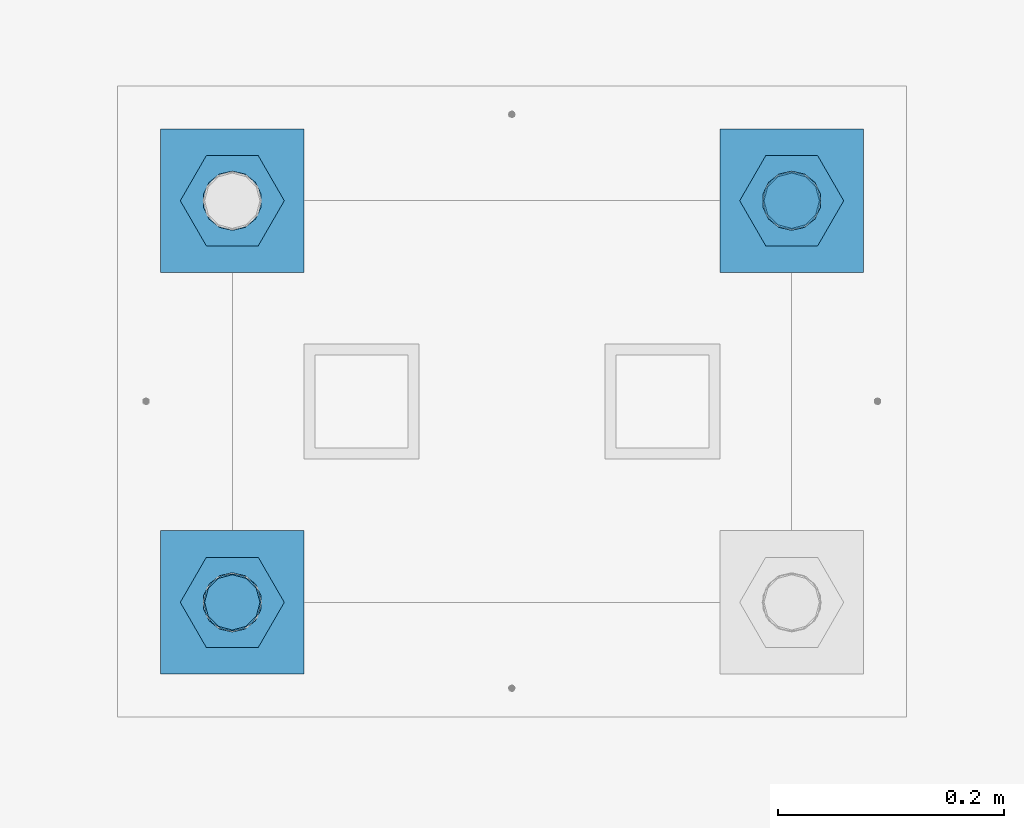
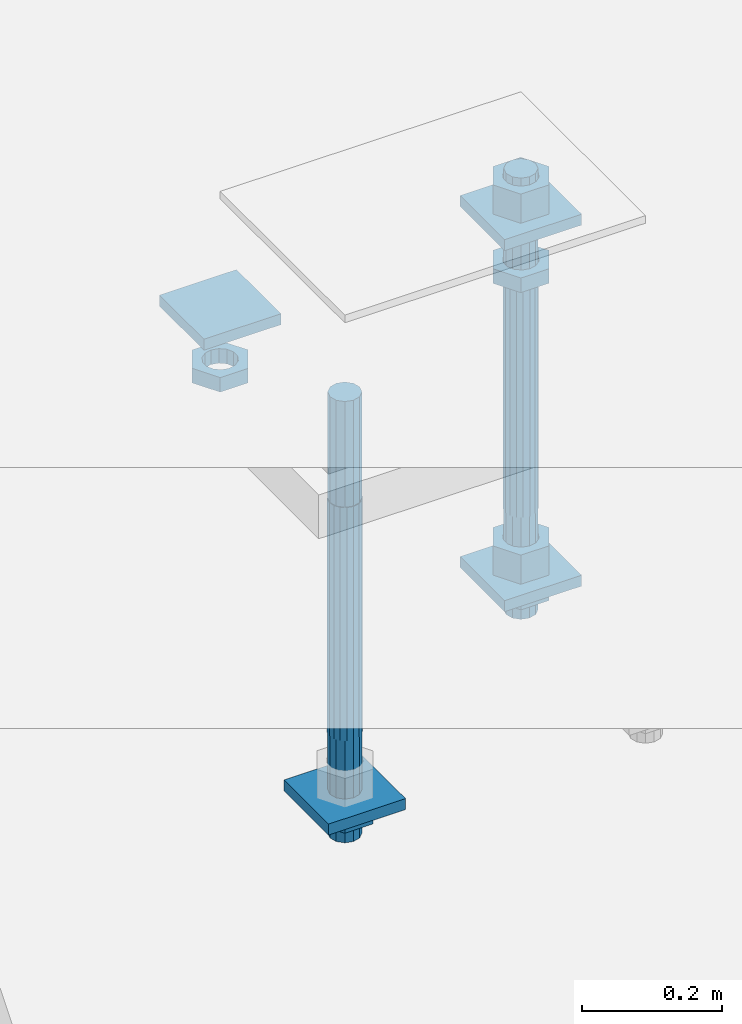
# One storey, part 2717 of 3843: 12 beams, 1 element without a shape of its own.
"""IFC2X3 building model written with IfcOpenShell, lengths in millimetres."""

from ifc_helpers import new_model, si_unit, frame, origin_with_axes, place, context, subcontext, project, spatial, faceted_brep, material, type_object, element, aggregate, save


model = new_model("IFC2X3")

# Units and contexts
model_context = context("Model", 3, precision=1e-05, world=origin_with_axes())
body_context = subcontext(model_context, "Body", "Model", "MODEL_VIEW")
ifc_project = project(units=[si_unit("LENGTHUNIT", "METRE", prefix="MILLI"), si_unit("AREAUNIT", "SQUARE_METRE"), si_unit("VOLUMEUNIT", "CUBIC_METRE"), si_unit("MASSUNIT", "GRAM", prefix="KILO"), si_unit("TIMEUNIT", "SECOND"), si_unit("PLANEANGLEUNIT", "RADIAN"), si_unit("SOLIDANGLEUNIT", "STERADIAN"), si_unit("THERMODYNAMICTEMPERATUREUNIT", "DEGREE_CELSIUS"), si_unit("LUMINOUSINTENSITYUNIT", "LUMEN")], contexts=[model_context])

# Site, building, storey
site_placement = place(None, origin_with_axes())
site = spatial("IfcSite", under=ifc_project, at=site_placement, CompositionType="ELEMENT")
building_placement = place(site_placement, origin_with_axes())
building = spatial("IfcBuilding", under=site, at=building_placement, Name="Undefined", CompositionType="ELEMENT")
storey_placement = place(building_placement, origin_with_axes())
storey = spatial("IfcBuildingStorey", under=building, at=storey_placement, Name="Undefined", CompositionType="ELEMENT", Elevation=0.0)

# Assembly, beams
assembly_placement = place(storey_placement, origin_with_axes())
assembly = element("IfcElementAssembly", 1, at=assembly_placement, inside=storey, Name="TEMPLATE", AssemblyPlace="NOTDEFINED", PredefinedType="RIGID_FRAME")
ifc_material_1 = material(Name="STEEL/A572-50")
beam_type_1 = type_object("IfcBeamType", PredefinedType="NOTDEFINED")
beam_1_placement = place(assembly_placement, frame((105403.65, 52946.2999984741, 29873.575), z_axis=(-1.0, 0.0, 0.0), x_axis=(0.0, -1.0, 0.0)))
beam_1 = element("IfcBeam", 2, at=beam_1_placement, type_object=beam_type_1, material=ifc_material_1, Name="WASHER_PLATE", context=body_context, shape_type="Brep", body=[
    faceted_brep([(0.0, 9.52500000000146, -63.5), (0.0, 9.52500000000146, 63.5), (127.0, 9.52500000000146, 63.5), (127.0, 9.52500000000146, -63.5), (0.0, -9.52500000000146, 63.5), (127.0, -9.52500000000146, 63.5), (0.0, -9.52500000000146, -63.5), (127.0, -9.52500000000146, -63.5)], [[[0, 1, 2, 3]], [[1, 4, 5, 2]], [[4, 6, 7, 5]], [[6, 0, 3, 7]], [[5, 7, 3, 2]], [[6, 4, 1, 0]]]),
])
beam_2_placement = place(assembly_placement, frame((104908.35, 52946.2999984741, 29873.575), z_axis=(-1.0, 0.0, 0.0), x_axis=(0.0, -1.0, 0.0)))
beam_2 = element("IfcBeam", 3, at=beam_2_placement, type_object=beam_type_1, material=ifc_material_1, Name="WASHER_PLATE", context=body_context, shape_type="Brep", body=[
    faceted_brep([(0.0, 9.52500000000146, -63.5), (0.0, 9.52500000000146, 63.5), (127.0, 9.52500000000146, 63.5), (127.0, 9.52500000000146, -63.5), (0.0, -9.52500000000146, 63.5), (127.0, -9.52500000000146, 63.5), (0.0, -9.52500000000146, -63.5), (127.0, -9.52500000000146, -63.5)], [[[0, 1, 2, 3]], [[1, 4, 5, 2]], [[4, 6, 7, 5]], [[6, 0, 3, 7]], [[5, 7, 3, 2]], [[6, 4, 1, 0]]]),
])
beam_3_placement = place(assembly_placement, frame((105403.65, 52946.2999984741, 29244.925), z_axis=(-1.0, 0.0, 0.0), x_axis=(0.0, -1.0, 0.0)))
beam_3 = element("IfcBeam", 4, at=beam_3_placement, type_object=beam_type_1, material=ifc_material_1, Name="WASHER_PLATE", context=body_context, shape_type="Brep", body=[
    faceted_brep([(0.0, 9.52500000000146, -63.5), (0.0, 9.52500000000146, 63.5), (127.0, 9.52500000000146, 63.5), (127.0, 9.52500000000146, -63.5), (0.0, -9.52500000000146, 63.5), (127.0, -9.52500000000146, 63.5), (0.0, -9.52500000000146, -63.5), (127.0, -9.52500000000146, -63.5)], [[[0, 1, 2, 3]], [[1, 4, 5, 2]], [[4, 6, 7, 5]], [[6, 0, 3, 7]], [[5, 7, 3, 2]], [[6, 4, 1, 0]]]),
])
beam_4_placement = place(assembly_placement, frame((104908.35, 52590.6999984741, 29244.925), z_axis=(-1.0, 0.0, 0.0), x_axis=(0.0, -1.0, 0.0)))
beam_4 = element("IfcBeam", 5, at=beam_4_placement, type_object=beam_type_1, material=ifc_material_1, Name="WASHER_PLATE", context=body_context, shape_type="Brep", body=[
    faceted_brep([(0.0, 9.52500000000146, -63.5), (0.0, 9.52500000000146, 63.5), (127.0, 9.52500000000146, 63.5), (127.0, 9.52500000000146, -63.5), (0.0, -9.52500000000146, 63.5), (127.0, -9.52500000000146, 63.5), (0.0, -9.52500000000146, -63.5), (127.0, -9.52500000000146, -63.5)], [[[0, 1, 2, 3]], [[1, 4, 5, 2]], [[4, 6, 7, 5]], [[6, 0, 3, 7]], [[5, 7, 3, 2]], [[6, 4, 1, 0]]]),
])
ifc_material_2 = material(Name="STEEL/A36")
beam_type_2 = type_object("IfcBeamType", Name="2_HALF_NUT", PredefinedType="NOTDEFINED")
beam_5_placement = place(assembly_placement, frame((105403.65, 52882.7999984741, 29787.85), z_axis=(0.0, -1.0, 0.0), x_axis=(0.0, 0.0, -1.0)))
beam_5 = element("IfcBeam", 6, at=beam_5_placement, type_object=beam_type_2, material=ifc_material_2, Name="NUT", ObjectType="2_HALF_NUT", context=body_context, shape_type="Brep", body=[
    faceted_brep([(0.0, -46.0369987487793, 0.0), (0.0, -23.0184993743896, -39.869213104248), (25.4000000000015, -23.0184993743896, -39.869213104248), (25.4000000000015, -46.0369987487793, 0.0), (0.0, 23.0184993743896, -39.869213104248), (25.4000000000015, 23.0184993743896, -39.869213104248), (0.0, 46.0369987487793, 0.0), (25.4000000000015, 46.0369987487793, 0.0), (0.0, 23.0184993743896, 39.869213104248), (25.4000000000015, 23.0184993743896, 39.869213104248), (0.0, -23.0184993743896, 39.869213104248), (25.4000000000015, -23.0184993743896, 39.869213104248), (0.0, 0.0, 26.1940002441406), (0.0, 11.3650617044477, 23.5999013092805), (25.4000000000015, 11.3650617044477, 23.5999013092805), (25.4000000000015, 0.0, 26.1940002441406), (0.0, 20.4791109456419, 16.3316083006721), (25.4000000000015, 20.4791109456419, 16.3316083006721), (0.0, 25.5370200498292, 5.82867859874386), (25.4000000000015, 25.5370200498292, 5.82867859874386), (0.0, 25.5370200498292, -5.82867859874386), (25.4000000000015, 25.5370200498292, -5.82867859874386), (0.0, 20.4791109456419, -16.3316083006721), (25.4000000000015, 20.4791109456419, -16.3316083006721), (0.0, 11.3650617044477, -23.5999013092805), (25.4000000000015, 11.3650617044477, -23.5999013092805), (0.0, 0.0, -26.1940002441406), (25.4000000000015, 0.0, -26.1940002441406), (0.0, -11.3650617044477, -23.5999013092805), (25.4000000000015, -11.3650617044477, -23.5999013092805), (0.0, -20.4791109456419, -16.3316083006721), (25.4000000000015, -20.4791109456419, -16.3316083006721), (0.0, -25.5370200498292, -5.82867859874386), (25.4000000000015, -25.5370200498292, -5.82867859874386), (0.0, -25.5370200498292, 5.82867859874386), (25.4000000000015, -25.5370200498292, 5.82867859874386), (0.0, -20.4791109456419, 16.3316083006721), (25.4000000000015, -20.4791109456419, 16.3316083006721), (0.0, -11.3650617044477, 23.5999013092805), (25.4000000000015, -11.3650617044477, 23.5999013092805)], [[[0, 1, 2, 3]], [[1, 4, 5, 2]], [[4, 6, 7, 5]], [[6, 8, 9, 7]], [[8, 10, 11, 9]], [[10, 0, 3, 11]], [[12, 13, 14, 15]], [[13, 16, 17, 14]], [[16, 18, 19, 17]], [[18, 20, 21, 19]], [[20, 22, 23, 21]], [[22, 24, 25, 23]], [[24, 26, 27, 25]], [[26, 28, 29, 27]], [[28, 30, 31, 29]], [[30, 32, 33, 31]], [[32, 34, 35, 33]], [[34, 36, 37, 35]], [[36, 38, 39, 37]], [[38, 12, 15, 39]], [[5, 7, 9, 11, 3, 2], [17, 19, 21, 23, 25, 27, 29, 31, 33, 35, 37, 39, 15, 14]], [[10, 8, 6, 4, 1, 0], [38, 36, 34, 32, 30, 28, 26, 24, 22, 20, 18, 16, 13, 12]]]),
])
beam_6_placement = place(assembly_placement, frame((105403.65, 52882.7999984741, 29235.4), z_axis=(0.0, -1.0, 0.0), x_axis=(0.0, 0.0, -1.0)))
beam_6 = element("IfcBeam", 7, at=beam_6_placement, type_object=beam_type_2, material=ifc_material_2, Name="NUT", ObjectType="2_HALF_NUT", context=body_context, shape_type="Brep", body=[
    faceted_brep([(0.0, -46.0369987487793, 0.0), (0.0, -23.0184993743896, -39.869213104248), (25.4000000000015, -23.0184993743896, -39.869213104248), (25.4000000000015, -46.0369987487793, 0.0), (0.0, 23.0184993743896, -39.869213104248), (25.4000000000015, 23.0184993743896, -39.869213104248), (0.0, 46.0369987487793, 0.0), (25.4000000000015, 46.0369987487793, 0.0), (0.0, 23.0184993743896, 39.869213104248), (25.4000000000015, 23.0184993743896, 39.869213104248), (0.0, -23.0184993743896, 39.869213104248), (25.4000000000015, -23.0184993743896, 39.869213104248), (0.0, 0.0, 26.1940002441406), (0.0, 11.3650617044477, 23.5999013092805), (25.4000000000015, 11.3650617044477, 23.5999013092805), (25.4000000000015, 0.0, 26.1940002441406), (0.0, 20.4791109456419, 16.3316083006721), (25.4000000000015, 20.4791109456419, 16.3316083006721), (0.0, 25.5370200498292, 5.82867859874386), (25.4000000000015, 25.5370200498292, 5.82867859874386), (0.0, 25.5370200498292, -5.82867859874386), (25.4000000000015, 25.5370200498292, -5.82867859874386), (0.0, 20.4791109456419, -16.3316083006721), (25.4000000000015, 20.4791109456419, -16.3316083006721), (0.0, 11.3650617044477, -23.5999013092805), (25.4000000000015, 11.3650617044477, -23.5999013092805), (0.0, 0.0, -26.1940002441406), (25.4000000000015, 0.0, -26.1940002441406), (0.0, -11.3650617044477, -23.5999013092805), (25.4000000000015, -11.3650617044477, -23.5999013092805), (0.0, -20.4791109456419, -16.3316083006721), (25.4000000000015, -20.4791109456419, -16.3316083006721), (0.0, -25.5370200498292, -5.82867859874386), (25.4000000000015, -25.5370200498292, -5.82867859874386), (0.0, -25.5370200498292, 5.82867859874386), (25.4000000000015, -25.5370200498292, 5.82867859874386), (0.0, -20.4791109456419, 16.3316083006721), (25.4000000000015, -20.4791109456419, 16.3316083006721), (0.0, -11.3650617044477, 23.5999013092805), (25.4000000000015, -11.3650617044477, 23.5999013092805)], [[[0, 1, 2, 3]], [[1, 4, 5, 2]], [[4, 6, 7, 5]], [[6, 8, 9, 7]], [[8, 10, 11, 9]], [[10, 0, 3, 11]], [[12, 13, 14, 15]], [[13, 16, 17, 14]], [[16, 18, 19, 17]], [[18, 20, 21, 19]], [[20, 22, 23, 21]], [[22, 24, 25, 23]], [[24, 26, 27, 25]], [[26, 28, 29, 27]], [[28, 30, 31, 29]], [[30, 32, 33, 31]], [[32, 34, 35, 33]], [[34, 36, 37, 35]], [[36, 38, 39, 37]], [[38, 12, 15, 39]], [[5, 7, 9, 11, 3, 2], [17, 19, 21, 23, 25, 27, 29, 31, 33, 35, 37, 39, 15, 14]], [[10, 8, 6, 4, 1, 0], [38, 36, 34, 32, 30, 28, 26, 24, 22, 20, 18, 16, 13, 12]]]),
])
beam_7_placement = place(assembly_placement, frame((104908.35, 52882.7999984741, 29787.85), z_axis=(0.0, -1.0, 0.0), x_axis=(0.0, 0.0, -1.0)))
beam_7 = element("IfcBeam", 8, at=beam_7_placement, type_object=beam_type_2, material=ifc_material_2, Name="NUT", ObjectType="2_HALF_NUT", context=body_context, shape_type="Brep", body=[
    faceted_brep([(0.0, -46.0369987487793, 0.0), (0.0, -23.0184993743896, -39.869213104248), (25.4000000000015, -23.0184993743896, -39.869213104248), (25.4000000000015, -46.0369987487793, 0.0), (0.0, 23.0184993743896, -39.869213104248), (25.4000000000015, 23.0184993743896, -39.869213104248), (0.0, 46.0369987487793, 0.0), (25.4000000000015, 46.0369987487793, 0.0), (0.0, 23.0184993743896, 39.869213104248), (25.4000000000015, 23.0184993743896, 39.869213104248), (0.0, -23.0184993743896, 39.869213104248), (25.4000000000015, -23.0184993743896, 39.869213104248), (0.0, 0.0, 26.1940002441406), (0.0, 11.3650617044477, 23.5999013092805), (25.4000000000015, 11.3650617044477, 23.5999013092805), (25.4000000000015, 0.0, 26.1940002441406), (0.0, 20.4791109456419, 16.3316083006721), (25.4000000000015, 20.4791109456419, 16.3316083006721), (0.0, 25.5370200498292, 5.82867859874386), (25.4000000000015, 25.5370200498292, 5.82867859874386), (0.0, 25.5370200498292, -5.82867859874386), (25.4000000000015, 25.5370200498292, -5.82867859874386), (0.0, 20.4791109456419, -16.3316083006721), (25.4000000000015, 20.4791109456419, -16.3316083006721), (0.0, 11.3650617044477, -23.5999013092805), (25.4000000000015, 11.3650617044477, -23.5999013092805), (0.0, 0.0, -26.1940002441406), (25.4000000000015, 0.0, -26.1940002441406), (0.0, -11.3650617044477, -23.5999013092805), (25.4000000000015, -11.3650617044477, -23.5999013092805), (0.0, -20.4791109456419, -16.3316083006721), (25.4000000000015, -20.4791109456419, -16.3316083006721), (0.0, -25.5370200498292, -5.82867859874386), (25.4000000000015, -25.5370200498292, -5.82867859874386), (0.0, -25.5370200498292, 5.82867859874386), (25.4000000000015, -25.5370200498292, 5.82867859874386), (0.0, -20.4791109456419, 16.3316083006721), (25.4000000000015, -20.4791109456419, 16.3316083006721), (0.0, -11.3650617044477, 23.5999013092805), (25.4000000000015, -11.3650617044477, 23.5999013092805)], [[[0, 1, 2, 3]], [[1, 4, 5, 2]], [[4, 6, 7, 5]], [[6, 8, 9, 7]], [[8, 10, 11, 9]], [[10, 0, 3, 11]], [[12, 13, 14, 15]], [[13, 16, 17, 14]], [[16, 18, 19, 17]], [[18, 20, 21, 19]], [[20, 22, 23, 21]], [[22, 24, 25, 23]], [[24, 26, 27, 25]], [[26, 28, 29, 27]], [[28, 30, 31, 29]], [[30, 32, 33, 31]], [[32, 34, 35, 33]], [[34, 36, 37, 35]], [[36, 38, 39, 37]], [[38, 12, 15, 39]], [[5, 7, 9, 11, 3, 2], [17, 19, 21, 23, 25, 27, 29, 31, 33, 35, 37, 39, 15, 14]], [[10, 8, 6, 4, 1, 0], [38, 36, 34, 32, 30, 28, 26, 24, 22, 20, 18, 16, 13, 12]]]),
])
beam_8_placement = place(assembly_placement, frame((104908.35, 52527.1999984741, 29235.4), z_axis=(0.0, -1.0, 0.0), x_axis=(0.0, 0.0, -1.0)))
beam_8 = element("IfcBeam", 9, at=beam_8_placement, type_object=beam_type_2, material=ifc_material_2, Name="NUT", ObjectType="2_HALF_NUT", context=body_context, shape_type="Brep", body=[
    faceted_brep([(0.0, -46.0369987487793, 0.0), (0.0, -23.0184993743896, -39.869213104248), (25.4000000000015, -23.0184993743896, -39.869213104248), (25.4000000000015, -46.0369987487793, 0.0), (0.0, 23.0184993743896, -39.869213104248), (25.4000000000015, 23.0184993743896, -39.869213104248), (0.0, 46.0369987487793, 0.0), (25.4000000000015, 46.0369987487793, 0.0), (0.0, 23.0184993743896, 39.869213104248), (25.4000000000015, 23.0184993743896, 39.869213104248), (0.0, -23.0184993743896, 39.869213104248), (25.4000000000015, -23.0184993743896, 39.869213104248), (0.0, 0.0, 26.1940002441406), (0.0, 11.3650617044477, 23.5999013092805), (25.4000000000015, 11.3650617044477, 23.5999013092805), (25.4000000000015, 0.0, 26.1940002441406), (0.0, 20.4791109456419, 16.3316083006721), (25.4000000000015, 20.4791109456419, 16.3316083006721), (0.0, 25.5370200498292, 5.82867859874386), (25.4000000000015, 25.5370200498292, 5.82867859874386), (0.0, 25.5370200498292, -5.82867859874386), (25.4000000000015, 25.5370200498292, -5.82867859874386), (0.0, 20.4791109456419, -16.3316083006721), (25.4000000000015, 20.4791109456419, -16.3316083006721), (0.0, 11.3650617044477, -23.5999013092805), (25.4000000000015, 11.3650617044477, -23.5999013092805), (0.0, 0.0, -26.1940002441406), (25.4000000000015, 0.0, -26.1940002441406), (0.0, -11.3650617044477, -23.5999013092805), (25.4000000000015, -11.3650617044477, -23.5999013092805), (0.0, -20.4791109456419, -16.3316083006721), (25.4000000000015, -20.4791109456419, -16.3316083006721), (0.0, -25.5370200498292, -5.82867859874386), (25.4000000000015, -25.5370200498292, -5.82867859874386), (0.0, -25.5370200498292, 5.82867859874386), (25.4000000000015, -25.5370200498292, 5.82867859874386), (0.0, -20.4791109456419, 16.3316083006721), (25.4000000000015, -20.4791109456419, 16.3316083006721), (0.0, -11.3650617044477, 23.5999013092805), (25.4000000000015, -11.3650617044477, 23.5999013092805)], [[[0, 1, 2, 3]], [[1, 4, 5, 2]], [[4, 6, 7, 5]], [[6, 8, 9, 7]], [[8, 10, 11, 9]], [[10, 0, 3, 11]], [[12, 13, 14, 15]], [[13, 16, 17, 14]], [[16, 18, 19, 17]], [[18, 20, 21, 19]], [[20, 22, 23, 21]], [[22, 24, 25, 23]], [[24, 26, 27, 25]], [[26, 28, 29, 27]], [[28, 30, 31, 29]], [[30, 32, 33, 31]], [[32, 34, 35, 33]], [[34, 36, 37, 35]], [[36, 38, 39, 37]], [[38, 12, 15, 39]], [[5, 7, 9, 11, 3, 2], [17, 19, 21, 23, 25, 27, 29, 31, 33, 35, 37, 39, 15, 14]], [[10, 8, 6, 4, 1, 0], [38, 36, 34, 32, 30, 28, 26, 24, 22, 20, 18, 16, 13, 12]]]),
])
beam_type_3 = type_object("IfcBeamType", Name="2_HEAVY_HEX_NUT", PredefinedType="NOTDEFINED")
beam_9_placement = place(assembly_placement, frame((105403.65, 52882.7999984741, 29933.9), z_axis=(0.0, -1.0, 0.0), x_axis=(0.0, 0.0, -1.0)))
beam_9 = element("IfcBeam", 10, at=beam_9_placement, type_object=beam_type_3, material=ifc_material_2, Name="NUT", ObjectType="2_HEAVY_HEX_NUT", context=body_context, shape_type="Brep", body=[
    faceted_brep([(0.0, -46.0369987487793, 0.0), (0.0, -23.0184993743896, -39.869213104248), (50.7999999999993, -23.0184993743896, -39.869213104248), (50.7999999999993, -46.0369987487793, 0.0), (0.0, 23.0184993743896, -39.869213104248), (50.7999999999993, 23.0184993743896, -39.869213104248), (0.0, 46.0369987487793, 0.0), (50.7999999999993, 46.0369987487793, 0.0), (0.0, 23.0184993743896, 39.869213104248), (50.7999999999993, 23.0184993743896, 39.869213104248), (0.0, -23.0184993743896, 39.869213104248), (50.7999999999993, -23.0184993743896, 39.869213104248), (0.0, 0.0, 26.1940002441406), (0.0, 11.3650617044477, 23.5999013092805), (50.7999999999993, 11.3650617044477, 23.5999013092805), (50.7999999999993, 0.0, 26.1940002441406), (0.0, 20.4791109456419, 16.3316083006721), (50.7999999999993, 20.4791109456419, 16.3316083006721), (0.0, 25.5370200498292, 5.82867859874386), (50.7999999999993, 25.5370200498292, 5.82867859874386), (0.0, 25.5370200498292, -5.82867859874386), (50.7999999999993, 25.5370200498292, -5.82867859874386), (0.0, 20.4791109456419, -16.3316083006721), (50.7999999999993, 20.4791109456419, -16.3316083006721), (0.0, 11.3650617044477, -23.5999013092805), (50.7999999999993, 11.3650617044477, -23.5999013092805), (0.0, 0.0, -26.1940002441406), (50.7999999999993, 0.0, -26.1940002441406), (0.0, -11.3650617044477, -23.5999013092805), (50.7999999999993, -11.3650617044477, -23.5999013092805), (0.0, -20.4791109456419, -16.3316083006721), (50.7999999999993, -20.4791109456419, -16.3316083006721), (0.0, -25.5370200498292, -5.82867859874386), (50.7999999999993, -25.5370200498292, -5.82867859874386), (0.0, -25.5370200498292, 5.82867859874386), (50.7999999999993, -25.5370200498292, 5.82867859874386), (0.0, -20.4791109456419, 16.3316083006721), (50.7999999999993, -20.4791109456419, 16.3316083006721), (0.0, -11.3650617044477, 23.5999013092805), (50.7999999999993, -11.3650617044477, 23.5999013092805)], [[[0, 1, 2, 3]], [[1, 4, 5, 2]], [[4, 6, 7, 5]], [[6, 8, 9, 7]], [[8, 10, 11, 9]], [[10, 0, 3, 11]], [[12, 13, 14, 15]], [[13, 16, 17, 14]], [[16, 18, 19, 17]], [[18, 20, 21, 19]], [[20, 22, 23, 21]], [[22, 24, 25, 23]], [[24, 26, 27, 25]], [[26, 28, 29, 27]], [[28, 30, 31, 29]], [[30, 32, 33, 31]], [[32, 34, 35, 33]], [[34, 36, 37, 35]], [[36, 38, 39, 37]], [[38, 12, 15, 39]], [[5, 7, 9, 11, 3, 2], [17, 19, 21, 23, 25, 27, 29, 31, 33, 35, 37, 39, 15, 14]], [[10, 8, 6, 4, 1, 0], [38, 36, 34, 32, 30, 28, 26, 24, 22, 20, 18, 16, 13, 12]]]),
])
beam_10_placement = place(assembly_placement, frame((105403.65, 52882.7999984741, 29305.25), z_axis=(0.0, -1.0, 0.0), x_axis=(0.0, 0.0, -1.0)))
beam_10 = element("IfcBeam", 11, at=beam_10_placement, type_object=beam_type_3, material=ifc_material_2, Name="NUT", ObjectType="2_HEAVY_HEX_NUT", context=body_context, shape_type="Brep", body=[
    faceted_brep([(0.0, -46.0369987487793, 0.0), (0.0, -23.0184993743896, -39.869213104248), (50.7999999999993, -23.0184993743896, -39.869213104248), (50.7999999999993, -46.0369987487793, 0.0), (0.0, 23.0184993743896, -39.869213104248), (50.7999999999993, 23.0184993743896, -39.869213104248), (0.0, 46.0369987487793, 0.0), (50.7999999999993, 46.0369987487793, 0.0), (0.0, 23.0184993743896, 39.869213104248), (50.7999999999993, 23.0184993743896, 39.869213104248), (0.0, -23.0184993743896, 39.869213104248), (50.7999999999993, -23.0184993743896, 39.869213104248), (0.0, 0.0, 26.1940002441406), (0.0, 11.3650617044477, 23.5999013092805), (50.7999999999993, 11.3650617044477, 23.5999013092805), (50.7999999999993, 0.0, 26.1940002441406), (0.0, 20.4791109456419, 16.3316083006721), (50.7999999999993, 20.4791109456419, 16.3316083006721), (0.0, 25.5370200498292, 5.82867859874386), (50.7999999999993, 25.5370200498292, 5.82867859874386), (0.0, 25.5370200498292, -5.82867859874386), (50.7999999999993, 25.5370200498292, -5.82867859874386), (0.0, 20.4791109456419, -16.3316083006721), (50.7999999999993, 20.4791109456419, -16.3316083006721), (0.0, 11.3650617044477, -23.5999013092805), (50.7999999999993, 11.3650617044477, -23.5999013092805), (0.0, 0.0, -26.1940002441406), (50.7999999999993, 0.0, -26.1940002441406), (0.0, -11.3650617044477, -23.5999013092805), (50.7999999999993, -11.3650617044477, -23.5999013092805), (0.0, -20.4791109456419, -16.3316083006721), (50.7999999999993, -20.4791109456419, -16.3316083006721), (0.0, -25.5370200498292, -5.82867859874386), (50.7999999999993, -25.5370200498292, -5.82867859874386), (0.0, -25.5370200498292, 5.82867859874386), (50.7999999999993, -25.5370200498292, 5.82867859874386), (0.0, -20.4791109456419, 16.3316083006721), (50.7999999999993, -20.4791109456419, 16.3316083006721), (0.0, -11.3650617044477, 23.5999013092805), (50.7999999999993, -11.3650617044477, 23.5999013092805)], [[[0, 1, 2, 3]], [[1, 4, 5, 2]], [[4, 6, 7, 5]], [[6, 8, 9, 7]], [[8, 10, 11, 9]], [[10, 0, 3, 11]], [[12, 13, 14, 15]], [[13, 16, 17, 14]], [[16, 18, 19, 17]], [[18, 20, 21, 19]], [[20, 22, 23, 21]], [[22, 24, 25, 23]], [[24, 26, 27, 25]], [[26, 28, 29, 27]], [[28, 30, 31, 29]], [[30, 32, 33, 31]], [[32, 34, 35, 33]], [[34, 36, 37, 35]], [[36, 38, 39, 37]], [[38, 12, 15, 39]], [[5, 7, 9, 11, 3, 2], [17, 19, 21, 23, 25, 27, 29, 31, 33, 35, 37, 39, 15, 14]], [[10, 8, 6, 4, 1, 0], [38, 36, 34, 32, 30, 28, 26, 24, 22, 20, 18, 16, 13, 12]]]),
])
ifc_material_3 = material()
beam_type_4 = type_object("IfcBeamType", PredefinedType="NOTDEFINED")
beam_11_placement = place(assembly_placement, frame((105403.65, 52882.7999984741, 29762.45), z_axis=(0.0, -1.0, 0.0), x_axis=(0.0, 0.0, -1.0)))
beam_11 = element("IfcBeam", 12, at=beam_11_placement, type_object=beam_type_4, material=ifc_material_3, Name="ANCHOR_ROD", context=body_context, shape_type="Brep", body=[
    faceted_brep([(-184.150000000001, -21.217622392709, 12.25), (-184.150000000001, -12.2499999999854, 21.2176223927163), (-184.150000000001, 1.45519152283669e-11, 24.5), (-184.150000000001, 12.2500000000146, 21.2176223927163), (-184.150000000001, 21.2176223927381, 12.25), (-184.150000000001, 24.5000000000146, 0.0), (-184.150000000001, 21.2176223927381, -12.25), (-184.150000000001, 12.2500000000146, -21.2176223927163), (-184.150000000001, 1.45519152283669e-11, -24.5), (-184.150000000001, -12.2499999999854, -21.2176223927163), (-184.150000000001, -21.217622392709, -12.25), (-184.150000000001, -24.4999999999854, 0.0), (0.0, 24.5000000000146, 0.0), (0.0, 21.2176223927381, -12.25), (0.0, 12.2500000000146, -21.2176223927163), (0.0, 1.45519152283669e-11, -24.5), (0.0, -12.2499999999854, -21.2176223927163), (0.0, -21.217622392709, -12.25), (0.0, -24.4999999999854, 0.0), (0.0, -21.217622392709, 12.25), (0.0, -12.2499999999854, 21.2176223927163), (0.0, 1.45519152283669e-11, 24.5), (0.0, 12.2500000000146, 21.2176223927163), (0.0, 21.2176223927381, 12.25), (0.0, -23.4665401257807, 9.72015918207035), (0.0, -17.9605122421344, 17.9605122421417), (0.0, -9.72015918207762, 23.466540125788), (0.0, 0.0, 25.4000000000015), (0.0, 9.72015918207762, 23.466540125788), (0.0, 17.9605122421344, 17.9605122421417), (0.0, 23.4665401257807, 9.72015918207035), (0.0, 25.3999996185303, 0.0), (0.0, 23.4665401257807, -9.72015918207035), (0.0, 17.9605122421344, -17.9605122421417), (0.0, 9.72015918207762, -23.466540125788), (0.0, 0.0, -25.4000000000015), (0.0, -9.72015918207762, -23.466540125788), (0.0, -17.9605122421344, -17.9605122421417), (0.0, -23.4665401257807, -9.72015918207035), (0.0, -25.3999996185303, 0.0), (406.399999999998, -25.3999999999942, 0.0), (406.399999999998, -23.4665401257807, 9.72015918207035), (406.399999999998, -17.9605122421344, 17.9605122421417), (406.399999999998, -9.72015918207762, 23.466540125788), (406.399999999998, 0.0, 25.4000000000015), (406.399999999998, 9.72015918207762, 23.466540125788), (406.399999999998, 17.9605122421344, 17.9605122421417), (406.399999999998, 23.4665401257807, 9.72015918207035), (406.399999999998, 25.3999999999942, 0.0), (406.399999999998, 23.4665401257807, -9.72015918207035), (406.399999999998, 17.9605122421344, -17.9605122421417), (406.399999999998, 9.72015918207762, -23.466540125788), (406.399999999998, 0.0, -25.4000000000015), (406.399999999998, -9.72015918207762, -23.466540125788), (406.399999999998, -17.9605122421344, -17.9605122421417), (406.399999999998, -23.4665401257807, -9.72015918207035), (406.399999999998, -12.2499999999854, 21.2176223927163), (406.399999999998, 1.45519152283669e-11, 24.5), (406.399999999998, 12.2500000000146, 21.2176223927163), (406.399999999998, 21.2176223927381, 12.25), (406.399999999998, 24.5000000000146, 0.0), (406.399999999998, 21.2176223927381, -12.25), (406.399999999998, 12.2500000000146, -21.2176223927163), (406.399999999998, 1.45519152283669e-11, -24.5), (406.399999999998, -12.2499999999854, -21.2176223927163), (406.399999999998, -21.217622392709, -12.25), (406.399999999998, -24.4999999999854, 0.0), (406.399999999998, -21.217622392709, 12.25), (584.200000000001, -12.2499999999854, -21.2176223927163), (584.200000000001, 1.45519152283669e-11, -24.5), (584.200000000001, 12.2500000000146, -21.2176223927163), (584.200000000001, 21.2176223927381, -12.25), (584.200000000001, 24.5000000000146, 0.0), (584.200000000001, 21.2176223927381, 12.25), (584.200000000001, 12.2500000000146, 21.2176223927163), (584.200000000001, 1.45519152283669e-11, 24.5), (584.200000000001, -12.2499999999854, 21.2176223927163), (584.200000000001, -21.217622392709, 12.25), (584.200000000001, -24.4999999999854, 0.0), (584.200000000001, -21.217622392709, -12.25)], [[[0, 1, 2, 3, 4, 5, 6, 7, 8, 9, 10, 11]], [[6, 5, 12, 13]], [[7, 6, 13, 14]], [[8, 7, 14, 15]], [[9, 8, 15, 16]], [[10, 9, 16, 17]], [[11, 10, 17, 18]], [[0, 11, 18, 19]], [[1, 0, 19, 20]], [[2, 1, 20, 21]], [[3, 2, 21, 22]], [[4, 3, 22, 23]], [[5, 4, 23, 12]], [[24, 25, 26, 27, 28, 29, 30, 31, 32, 33, 34, 35, 36, 37, 38, 39], [22, 21, 20, 19, 18, 17, 16, 15, 14, 13, 12, 23]], [[24, 39, 40, 41]], [[25, 24, 41, 42]], [[26, 25, 42, 43]], [[27, 26, 43, 44]], [[28, 27, 44, 45]], [[29, 28, 45, 46]], [[30, 29, 46, 47]], [[31, 30, 47, 48]], [[32, 31, 48, 49]], [[33, 32, 49, 50]], [[34, 33, 50, 51]], [[35, 34, 51, 52]], [[36, 35, 52, 53]], [[37, 36, 53, 54]], [[38, 37, 54, 55]], [[39, 38, 55, 40]], [[54, 53, 52, 51, 50, 49, 48, 47, 46, 45, 44, 43, 42, 41, 40, 55], [56, 57, 58, 59, 60, 61, 62, 63, 64, 65, 66, 67]], [[68, 69, 70, 71, 72, 73, 74, 75, 76, 77, 78, 79]], [[76, 75, 57, 56]], [[77, 76, 56, 67]], [[78, 77, 67, 66]], [[79, 78, 66, 65]], [[68, 79, 65, 64]], [[69, 68, 64, 63]], [[70, 69, 63, 62]], [[71, 70, 62, 61]], [[72, 71, 61, 60]], [[73, 72, 60, 59]], [[74, 73, 59, 58]], [[75, 74, 58, 57]]]),
])
beam_12_placement = place(assembly_placement, frame((104908.35, 52527.1999984741, 29762.45), z_axis=(0.0, -1.0, 0.0), x_axis=(0.0, 0.0, -1.0)))
beam_12 = element("IfcBeam", 13, at=beam_12_placement, type_object=beam_type_4, material=ifc_material_3, Name="ANCHOR_ROD", context=body_context, shape_type="Brep", body=[
    faceted_brep([(-184.150000000001, -21.217622392709, 12.25), (-184.150000000001, -12.2499999999854, 21.2176223927163), (-184.150000000001, 1.45519152283669e-11, 24.5), (-184.150000000001, 12.2500000000146, 21.2176223927163), (-184.150000000001, 21.2176223927381, 12.25), (-184.150000000001, 24.5000000000146, 0.0), (-184.150000000001, 21.2176223927381, -12.25), (-184.150000000001, 12.2500000000146, -21.2176223927163), (-184.150000000001, 1.45519152283669e-11, -24.5), (-184.150000000001, -12.2499999999854, -21.2176223927163), (-184.150000000001, -21.217622392709, -12.25), (-184.150000000001, -24.4999999999854, 0.0), (0.0, 24.5000000000146, 0.0), (0.0, 21.2176223927381, -12.25), (0.0, 12.2500000000146, -21.2176223927163), (0.0, 1.45519152283669e-11, -24.5), (0.0, -12.2499999999854, -21.2176223927163), (0.0, -21.217622392709, -12.25), (0.0, -24.4999999999854, 0.0), (0.0, -21.217622392709, 12.25), (0.0, -12.2499999999854, 21.2176223927163), (0.0, 1.45519152283669e-11, 24.5), (0.0, 12.2500000000146, 21.2176223927163), (0.0, 21.2176223927381, 12.25), (0.0, -23.4665401257807, 9.72015918207035), (0.0, -17.9605122421344, 17.9605122421417), (0.0, -9.72015918207762, 23.466540125788), (0.0, 0.0, 25.4000000000015), (0.0, 9.72015918207762, 23.466540125788), (0.0, 17.9605122421344, 17.9605122421417), (0.0, 23.4665401257807, 9.72015918207035), (0.0, 25.3999996185303, 0.0), (0.0, 23.4665401257807, -9.72015918207035), (0.0, 17.9605122421344, -17.9605122421417), (0.0, 9.72015918207762, -23.466540125788), (0.0, 0.0, -25.4000000000015), (0.0, -9.72015918207762, -23.466540125788), (0.0, -17.9605122421344, -17.9605122421417), (0.0, -23.4665401257807, -9.72015918207035), (0.0, -25.3999996185303, 0.0), (406.399999999998, -25.3999999999942, 0.0), (406.399999999998, -23.4665401257807, 9.72015918207035), (406.399999999998, -17.9605122421344, 17.9605122421417), (406.399999999998, -9.72015918207762, 23.466540125788), (406.399999999998, 0.0, 25.4000000000015), (406.399999999998, 9.72015918207762, 23.466540125788), (406.399999999998, 17.9605122421344, 17.9605122421417), (406.399999999998, 23.4665401257807, 9.72015918207035), (406.399999999998, 25.3999999999942, 0.0), (406.399999999998, 23.4665401257807, -9.72015918207035), (406.399999999998, 17.9605122421344, -17.9605122421417), (406.399999999998, 9.72015918207762, -23.466540125788), (406.399999999998, 0.0, -25.4000000000015), (406.399999999998, -9.72015918207762, -23.466540125788), (406.399999999998, -17.9605122421344, -17.9605122421417), (406.399999999998, -23.4665401257807, -9.72015918207035), (406.399999999998, -12.2499999999854, 21.2176223927163), (406.399999999998, 1.45519152283669e-11, 24.5), (406.399999999998, 12.2500000000146, 21.2176223927163), (406.399999999998, 21.2176223927381, 12.25), (406.399999999998, 24.5000000000146, 0.0), (406.399999999998, 21.2176223927381, -12.25), (406.399999999998, 12.2500000000146, -21.2176223927163), (406.399999999998, 1.45519152283669e-11, -24.5), (406.399999999998, -12.2499999999854, -21.2176223927163), (406.399999999998, -21.217622392709, -12.25), (406.399999999998, -24.4999999999854, 0.0), (406.399999999998, -21.217622392709, 12.25), (584.200000000001, -12.2499999999854, -21.2176223927163), (584.200000000001, 1.45519152283669e-11, -24.5), (584.200000000001, 12.2500000000146, -21.2176223927163), (584.200000000001, 21.2176223927381, -12.25), (584.200000000001, 24.5000000000146, 0.0), (584.200000000001, 21.2176223927381, 12.25), (584.200000000001, 12.2500000000146, 21.2176223927163), (584.200000000001, 1.45519152283669e-11, 24.5), (584.200000000001, -12.2499999999854, 21.2176223927163), (584.200000000001, -21.217622392709, 12.25), (584.200000000001, -24.4999999999854, 0.0), (584.200000000001, -21.217622392709, -12.25)], [[[0, 1, 2, 3, 4, 5, 6, 7, 8, 9, 10, 11]], [[6, 5, 12, 13]], [[7, 6, 13, 14]], [[8, 7, 14, 15]], [[9, 8, 15, 16]], [[10, 9, 16, 17]], [[11, 10, 17, 18]], [[0, 11, 18, 19]], [[1, 0, 19, 20]], [[2, 1, 20, 21]], [[3, 2, 21, 22]], [[4, 3, 22, 23]], [[5, 4, 23, 12]], [[24, 25, 26, 27, 28, 29, 30, 31, 32, 33, 34, 35, 36, 37, 38, 39], [22, 21, 20, 19, 18, 17, 16, 15, 14, 13, 12, 23]], [[24, 39, 40, 41]], [[25, 24, 41, 42]], [[26, 25, 42, 43]], [[27, 26, 43, 44]], [[28, 27, 44, 45]], [[29, 28, 45, 46]], [[30, 29, 46, 47]], [[31, 30, 47, 48]], [[32, 31, 48, 49]], [[33, 32, 49, 50]], [[34, 33, 50, 51]], [[35, 34, 51, 52]], [[36, 35, 52, 53]], [[37, 36, 53, 54]], [[38, 37, 54, 55]], [[39, 38, 55, 40]], [[54, 53, 52, 51, 50, 49, 48, 47, 46, 45, 44, 43, 42, 41, 40, 55], [56, 57, 58, 59, 60, 61, 62, 63, 64, 65, 66, 67]], [[68, 69, 70, 71, 72, 73, 74, 75, 76, 77, 78, 79]], [[76, 75, 57, 56]], [[77, 76, 56, 67]], [[78, 77, 67, 66]], [[79, 78, 66, 65]], [[68, 79, 65, 64]], [[69, 68, 64, 63]], [[70, 69, 63, 62]], [[71, 70, 62, 61]], [[72, 71, 61, 60]], [[73, 72, 60, 59]], [[74, 73, 59, 58]], [[75, 74, 58, 57]]]),
])
aggregate(assembly, [beam_1, beam_2, beam_5, beam_9, beam_10, beam_6, beam_3, beam_11, beam_7, beam_8, beam_4, beam_12])

save(model, "model.ifc")
